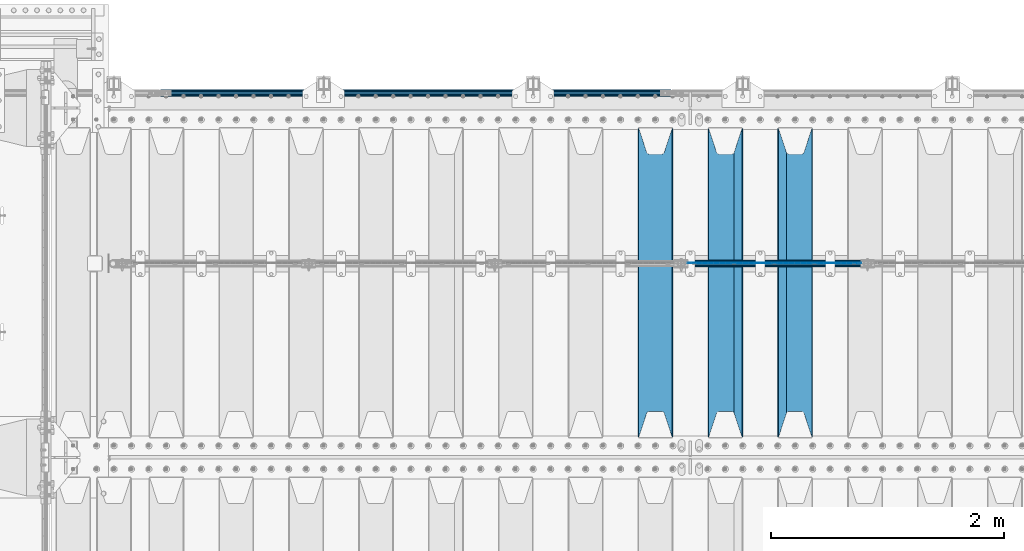
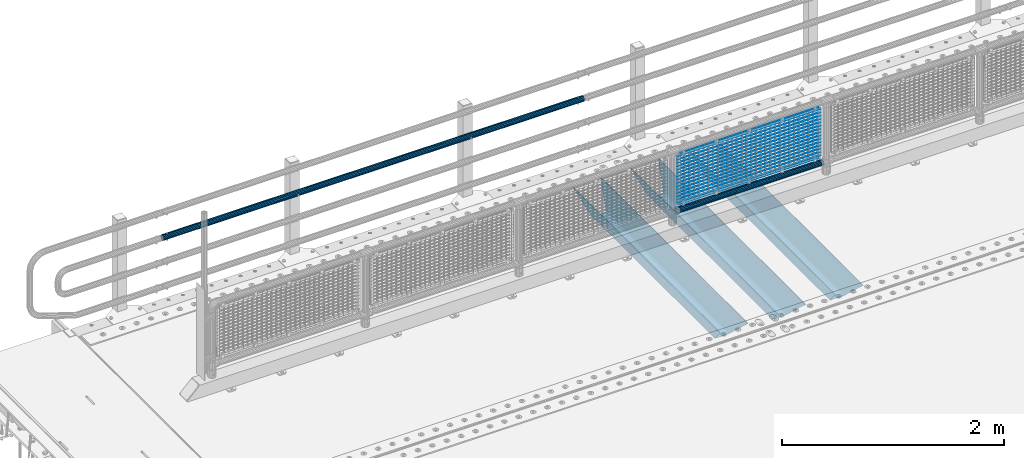
# One storey, part 123 of 247: 22 beams.
"""IFC2X3 building model written with IfcOpenShell, lengths in millimetres."""

from ifc_helpers import new_model, si_unit, frame, origin_with_axes, place, context, subcontext, project, spatial, faceted_brep, material, type_object, element, save


model = new_model("IFC2X3")

# Units and contexts
model_context = context("Model", 3, precision=1e-05, world=origin_with_axes())
body_context = subcontext(model_context, "Body", "Model", "MODEL_VIEW")
ifc_project = project(units=[si_unit("LENGTHUNIT", "METRE", prefix="MILLI"), si_unit("AREAUNIT", "SQUARE_METRE"), si_unit("VOLUMEUNIT", "CUBIC_METRE"), si_unit("MASSUNIT", "GRAM", prefix="KILO"), si_unit("TIMEUNIT", "SECOND"), si_unit("PLANEANGLEUNIT", "RADIAN"), si_unit("SOLIDANGLEUNIT", "STERADIAN"), si_unit("THERMODYNAMICTEMPERATUREUNIT", "DEGREE_CELSIUS"), si_unit("LUMINOUSINTENSITYUNIT", "LUMEN")], contexts=[model_context])

# Site, building, storey
site_placement = place(None, origin_with_axes())
site = spatial("IfcSite", under=ifc_project, at=site_placement, CompositionType="ELEMENT")
building_placement = place(site_placement, origin_with_axes())
building = spatial("IfcBuilding", under=site, at=building_placement, Name="Standard", CompositionType="ELEMENT")
storey_placement = place(building_placement, origin_with_axes())
storey = spatial("IfcBuildingStorey", under=building, at=storey_placement, Name="Undefined", CompositionType="ELEMENT", Elevation=0.0)

# Beams
ifc_material_1 = material(Name="STEEL/S355N")
beam_type_1 = type_object("IfcBeamType", PredefinedType="NOTDEFINED")
beam_1_placement = place(storey_placement, frame((6400.0, 6175.0, -115.0), z_axis=(0.0, 0.0, 1.0), x_axis=(0.0, 1.0, 0.0)))
element("IfcBeam", 1, at=beam_1_placement, inside=storey, type_object=beam_type_1, material=ifc_material_1, context=body_context, shape_type="Brep", body=[
    faceted_brep([(0.0, 150.0, 115.0), (0.0, 143.689999999999, 115.0), (2650.00000000297, 143.689999999999, 115.0), (2650.00000000297, 150.0, 115.0), (2650.00000000297, 142.059565218402, 110.0000000031), (2650.00000000297, 148.369565218403, 110.0000000031), (2441.90079219208, -80.1103600731112, -98.0992078077845), (2437.7588105432, -77.5672621345584, -102.241189456673), (2434.06523489746, -74.4080125315522, -105.934765102404), (2430.91086095089, -70.710272125576, -109.089139048974), (2428.37322971128, -66.5649389910068, -111.626770288588), (2426.51472138054, -62.0739139532889, -113.485278619323), (2425.38102192091, -57.3475956567672, -114.618978078955), (2424.99999999987, -52.5021667386536, -115.0), (2424.99999999987, 52.5021667386536, -115.0), (2425.38102192091, 57.3475956567672, -114.618978078955), (2426.51472138054, 62.0739139532889, -113.485278619323), (2428.37322971128, 66.5649389910068, -111.626770288588), (2430.91086095089, 70.710272125576, -109.089139048974), (2434.06523489746, 74.4080125315522, -105.934765102404), (2437.7588105432, 77.5672621345584, -102.241189456673), (2441.90079219208, 80.1103600731112, -98.0992078077846), (2446.38936140511, 81.9747917625791, -93.6106385947584), (2448.24948500409, 76.2713538057251, -91.7505149957729), (2444.62967112262, 74.76777986261, -95.3703288772456), (2441.28936334126, 72.7168944282894, -98.710636658607), (2438.31067330438, 70.1691124903846, -101.689326695487), (2435.76682334747, 67.1870637758839, -104.233176652398), (2433.72034654133, 63.8440531834895, -106.279653458539), (2432.22154950041, 60.222258798236, -107.778450499454), (2431.30727574265, 56.4107117849089, -108.692724257221), (2430.99999999987, 52.5031078186876, -109.0), (2430.99999999987, -52.5031078186876, -109.0), (2431.30727574265, -56.4107117849089, -108.692724257221), (2432.22154950041, -60.222258798236, -107.778450499454), (2433.72034654133, -63.8440531834895, -106.279653458539), (2435.76682334747, -67.1870637758839, -104.233176652398), (2438.31067330438, -70.1691124903846, -101.689326695487), (2441.28936334126, -72.7168944282894, -98.7106366586071), (2444.62967112262, -74.76777986261, -95.3703288772457), (2448.24948500409, -76.2713538057251, -91.7505149957729), (2650.00000000297, -142.059565218402, 110.0000000031), (2650.00000000297, -148.369565218403, 110.0000000031), (2446.38936140511, -81.9747917625791, -93.6106385947584), (2650.00000000297, -143.689999999999, 115.0), (2650.00000000297, -150.0, 115.0), (0.0, -143.689999999999, 115.0), (0.0, -150.0, 115.0), (0.0, -148.369565218261, 110.000000002663), (203.610638597422, -81.9747917625791, -93.6106385947584), (208.099207810448, -80.1103600731112, -98.0992078077845), (212.241189459336, -77.5672621345584, -102.241189456673), (215.934765105068, -74.4080125315522, -105.934765102404), (219.089139051637, -70.710272125576, -109.089139048974), (221.626770291251, -66.5649389910068, -111.626770288588), (223.485278621985, -62.0739139532889, -113.485278619323), (224.618978081617, -57.3475956567672, -114.618978078955), (225.000000002663, -52.5021667386536, -115.0), (225.000000002663, 52.5021667386536, -115.0), (224.618978081617, 57.3475956567672, -114.618978078955), (223.485278621985, 62.0739139532889, -113.485278619323), (221.626770291251, 66.5649389910068, -111.626770288588), (219.089139051637, 70.710272125576, -109.089139048974), (215.934765105068, 74.4080125315522, -105.934765102404), (212.241189459336, 77.5672621345584, -102.241189456673), (208.099207810448, 80.1103600731112, -98.0992078077846), (203.610638597422, 81.9747917625791, -93.6106385947584), (0.0, 148.369565218261, 110.000000002663), (0.0, 142.05956521826, 110.000000002663), (201.750514998436, 76.2713538057251, -91.7505149957729), (205.370328879908, 74.76777986261, -95.3703288772456), (208.710636661271, 72.7168944282894, -98.710636658607), (211.68932669815, 70.1691124903846, -101.689326695487), (214.233176655061, 67.1870637758839, -104.233176652398), (216.279653461202, 63.8440531834895, -106.279653458539), (217.778450502117, 60.222258798236, -107.778450499454), (218.692724259885, 56.4107117849089, -108.692724257221), (219.000000002663, 52.5031078186876, -109.0), (219.000000002663, -52.5031078186876, -109.0), (218.692724259885, -56.4107117849089, -108.692724257221), (217.778450502117, -60.222258798236, -107.778450499454), (216.279653461202, -63.8440531834895, -106.279653458539), (214.233176655061, -67.1870637758839, -104.233176652398), (211.68932669815, -70.1691124903846, -101.689326695487), (208.710636661271, -72.7168944282894, -98.7106366586071), (205.370328879908, -74.76777986261, -95.3703288772457), (201.750514998436, -76.2713538057251, -91.7505149957729), (0.0, -142.05956521826, 110.000000002663)], [[[0, 1, 2, 3]], [[3, 2, 4, 5]], [[6, 7, 8, 9, 10, 11, 12, 13, 14, 15, 16, 17, 18, 19, 20, 21, 22, 5, 4, 23, 24, 25, 26, 27, 28, 29, 30, 31, 32, 33, 34, 35, 36, 37, 38, 39, 40, 41, 42, 43]], [[44, 45, 42, 41]], [[46, 47, 45, 44]], [[43, 42, 45, 47, 48, 49]], [[6, 43, 49, 50]], [[7, 6, 50, 51]], [[8, 7, 51, 52]], [[9, 8, 52, 53]], [[10, 9, 53, 54]], [[11, 10, 54, 55]], [[12, 11, 55, 56]], [[13, 12, 56, 57]], [[14, 13, 57, 58]], [[15, 14, 58, 59]], [[16, 15, 59, 60]], [[17, 16, 60, 61]], [[18, 17, 61, 62]], [[19, 18, 62, 63]], [[20, 19, 63, 64]], [[21, 20, 64, 65]], [[22, 21, 65, 66]], [[0, 3, 5, 22, 66, 67]], [[1, 0, 67, 68]], [[23, 4, 2, 1, 68, 69]], [[24, 23, 69, 70]], [[25, 24, 70, 71]], [[26, 25, 71, 72]], [[27, 26, 72, 73]], [[28, 27, 73, 74]], [[29, 28, 74, 75]], [[30, 29, 75, 76]], [[31, 30, 76, 77]], [[32, 31, 77, 78]], [[33, 32, 78, 79]], [[34, 33, 79, 80]], [[35, 34, 80, 81]], [[36, 35, 81, 82]], [[37, 36, 82, 83]], [[38, 37, 83, 84]], [[39, 38, 84, 85]], [[40, 39, 85, 86]], [[46, 44, 41, 40, 86, 87]], [[47, 46, 87, 48]], [[86, 85, 84, 83, 82, 81, 80, 79, 78, 77, 76, 75, 74, 73, 72, 71, 70, 69, 68, 67, 66, 65, 64, 63, 62, 61, 60, 59, 58, 57, 56, 55, 54, 53, 52, 51, 50, 49, 48, 87]]]),
])
beam_2_placement = place(storey_placement, frame((5800.0, 6175.0, -115.0), z_axis=(0.0, 0.0, 1.0), x_axis=(0.0, 1.0, 0.0)))
element("IfcBeam", 2, at=beam_2_placement, inside=storey, type_object=beam_type_1, material=ifc_material_1, context=body_context, shape_type="Brep", body=[
    faceted_brep([(0.0, 150.0, 115.0), (0.0, 143.689999999999, 115.0), (2650.00000000297, 143.689999999999, 115.0), (2650.00000000297, 150.0, 115.0), (2650.00000000297, 142.059565218402, 110.0000000031), (2650.00000000297, 148.369565218403, 110.0000000031), (2441.90079219208, -80.1103600731112, -98.0992078077845), (2437.7588105432, -77.5672621345584, -102.241189456673), (2434.06523489746, -74.4080125315522, -105.934765102404), (2430.91086095089, -70.710272125576, -109.089139048974), (2428.37322971128, -66.5649389910068, -111.626770288588), (2426.51472138054, -62.0739139532889, -113.485278619323), (2425.38102192091, -57.3475956567672, -114.618978078955), (2424.99999999987, -52.5021667386536, -115.0), (2424.99999999987, 52.5021667386536, -115.0), (2425.38102192091, 57.3475956567672, -114.618978078955), (2426.51472138054, 62.0739139532889, -113.485278619323), (2428.37322971128, 66.5649389910068, -111.626770288588), (2430.91086095089, 70.710272125576, -109.089139048974), (2434.06523489746, 74.4080125315522, -105.934765102404), (2437.7588105432, 77.5672621345584, -102.241189456673), (2441.90079219208, 80.1103600731112, -98.0992078077846), (2446.38936140511, 81.9747917625791, -93.6106385947584), (2448.24948500409, 76.2713538057251, -91.7505149957729), (2444.62967112262, 74.76777986261, -95.3703288772456), (2441.28936334126, 72.7168944282894, -98.710636658607), (2438.31067330438, 70.1691124903846, -101.689326695487), (2435.76682334747, 67.1870637758839, -104.233176652398), (2433.72034654133, 63.8440531834895, -106.279653458539), (2432.22154950041, 60.222258798236, -107.778450499454), (2431.30727574265, 56.4107117849089, -108.692724257221), (2430.99999999987, 52.5031078186876, -109.0), (2430.99999999987, -52.5031078186876, -109.0), (2431.30727574265, -56.4107117849089, -108.692724257221), (2432.22154950041, -60.222258798236, -107.778450499454), (2433.72034654133, -63.8440531834895, -106.279653458539), (2435.76682334747, -67.1870637758839, -104.233176652398), (2438.31067330438, -70.1691124903846, -101.689326695487), (2441.28936334126, -72.7168944282894, -98.7106366586071), (2444.62967112262, -74.76777986261, -95.3703288772457), (2448.24948500409, -76.2713538057251, -91.7505149957729), (2650.00000000297, -142.059565218402, 110.0000000031), (2650.00000000297, -148.369565218403, 110.0000000031), (2446.38936140511, -81.9747917625791, -93.6106385947584), (2650.00000000297, -143.689999999999, 115.0), (2650.00000000297, -150.0, 115.0), (0.0, -143.689999999999, 115.0), (0.0, -150.0, 115.0), (0.0, -148.369565218261, 110.000000002663), (203.610638597422, -81.9747917625791, -93.6106385947584), (208.099207810448, -80.1103600731112, -98.0992078077845), (212.241189459336, -77.5672621345584, -102.241189456673), (215.934765105068, -74.4080125315522, -105.934765102404), (219.089139051637, -70.710272125576, -109.089139048974), (221.626770291251, -66.5649389910068, -111.626770288588), (223.485278621985, -62.0739139532889, -113.485278619323), (224.618978081617, -57.3475956567672, -114.618978078955), (225.000000002663, -52.5021667386536, -115.0), (225.000000002663, 52.5021667386536, -115.0), (224.618978081617, 57.3475956567672, -114.618978078955), (223.485278621985, 62.0739139532889, -113.485278619323), (221.626770291251, 66.5649389910068, -111.626770288588), (219.089139051637, 70.710272125576, -109.089139048974), (215.934765105068, 74.4080125315522, -105.934765102404), (212.241189459336, 77.5672621345584, -102.241189456673), (208.099207810448, 80.1103600731112, -98.0992078077846), (203.610638597422, 81.9747917625791, -93.6106385947584), (0.0, 148.369565218261, 110.000000002663), (0.0, 142.05956521826, 110.000000002663), (201.750514998436, 76.2713538057251, -91.7505149957729), (205.370328879908, 74.76777986261, -95.3703288772456), (208.710636661271, 72.7168944282894, -98.710636658607), (211.68932669815, 70.1691124903846, -101.689326695487), (214.233176655061, 67.1870637758839, -104.233176652398), (216.279653461202, 63.8440531834895, -106.279653458539), (217.778450502117, 60.222258798236, -107.778450499454), (218.692724259885, 56.4107117849089, -108.692724257221), (219.000000002663, 52.5031078186876, -109.0), (219.000000002663, -52.5031078186876, -109.0), (218.692724259885, -56.4107117849089, -108.692724257221), (217.778450502117, -60.222258798236, -107.778450499454), (216.279653461202, -63.8440531834895, -106.279653458539), (214.233176655061, -67.1870637758839, -104.233176652398), (211.68932669815, -70.1691124903846, -101.689326695487), (208.710636661271, -72.7168944282894, -98.7106366586071), (205.370328879908, -74.76777986261, -95.3703288772457), (201.750514998436, -76.2713538057251, -91.7505149957729), (0.0, -142.05956521826, 110.000000002663)], [[[0, 1, 2, 3]], [[3, 2, 4, 5]], [[6, 7, 8, 9, 10, 11, 12, 13, 14, 15, 16, 17, 18, 19, 20, 21, 22, 5, 4, 23, 24, 25, 26, 27, 28, 29, 30, 31, 32, 33, 34, 35, 36, 37, 38, 39, 40, 41, 42, 43]], [[44, 45, 42, 41]], [[46, 47, 45, 44]], [[43, 42, 45, 47, 48, 49]], [[6, 43, 49, 50]], [[7, 6, 50, 51]], [[8, 7, 51, 52]], [[9, 8, 52, 53]], [[10, 9, 53, 54]], [[11, 10, 54, 55]], [[12, 11, 55, 56]], [[13, 12, 56, 57]], [[14, 13, 57, 58]], [[15, 14, 58, 59]], [[16, 15, 59, 60]], [[17, 16, 60, 61]], [[18, 17, 61, 62]], [[19, 18, 62, 63]], [[20, 19, 63, 64]], [[21, 20, 64, 65]], [[22, 21, 65, 66]], [[0, 3, 5, 22, 66, 67]], [[1, 0, 67, 68]], [[23, 4, 2, 1, 68, 69]], [[24, 23, 69, 70]], [[25, 24, 70, 71]], [[26, 25, 71, 72]], [[27, 26, 72, 73]], [[28, 27, 73, 74]], [[29, 28, 74, 75]], [[30, 29, 75, 76]], [[31, 30, 76, 77]], [[32, 31, 77, 78]], [[33, 32, 78, 79]], [[34, 33, 79, 80]], [[35, 34, 80, 81]], [[36, 35, 81, 82]], [[37, 36, 82, 83]], [[38, 37, 83, 84]], [[39, 38, 84, 85]], [[40, 39, 85, 86]], [[46, 44, 41, 40, 86, 87]], [[47, 46, 87, 48]], [[86, 85, 84, 83, 82, 81, 80, 79, 78, 77, 76, 75, 74, 73, 72, 71, 70, 69, 68, 67, 66, 65, 64, 63, 62, 61, 60, 59, 58, 57, 56, 55, 54, 53, 52, 51, 50, 49, 48, 87]]]),
])
beam_3_placement = place(storey_placement, frame((5200.0, 6175.0, -115.0), z_axis=(0.0, 0.0, 1.0), x_axis=(0.0, 1.0, 0.0)))
element("IfcBeam", 3, at=beam_3_placement, inside=storey, type_object=beam_type_1, material=ifc_material_1, context=body_context, shape_type="Brep", body=[
    faceted_brep([(0.0, 150.0, 115.0), (0.0, 143.689999999999, 115.0), (2650.00000000297, 143.689999999999, 115.0), (2650.00000000297, 150.0, 115.0), (2650.00000000297, 142.059565218402, 110.0000000031), (2650.00000000297, 148.369565218403, 110.0000000031), (2441.90079219208, -80.1103600731112, -98.0992078077845), (2437.7588105432, -77.5672621345584, -102.241189456673), (2434.06523489746, -74.4080125315522, -105.934765102404), (2430.91086095089, -70.710272125576, -109.089139048974), (2428.37322971128, -66.5649389910068, -111.626770288588), (2426.51472138054, -62.0739139532889, -113.485278619323), (2425.38102192091, -57.3475956567672, -114.618978078955), (2424.99999999987, -52.5021667386536, -115.0), (2424.99999999987, 52.5021667386536, -115.0), (2425.38102192091, 57.3475956567672, -114.618978078955), (2426.51472138054, 62.0739139532889, -113.485278619323), (2428.37322971128, 66.5649389910068, -111.626770288588), (2430.91086095089, 70.710272125576, -109.089139048974), (2434.06523489746, 74.4080125315522, -105.934765102404), (2437.7588105432, 77.5672621345584, -102.241189456673), (2441.90079219208, 80.1103600731112, -98.0992078077846), (2446.38936140511, 81.9747917625791, -93.6106385947584), (2448.24948500409, 76.2713538057251, -91.7505149957729), (2444.62967112262, 74.76777986261, -95.3703288772456), (2441.28936334126, 72.7168944282894, -98.710636658607), (2438.31067330438, 70.1691124903846, -101.689326695487), (2435.76682334747, 67.1870637758839, -104.233176652398), (2433.72034654133, 63.8440531834895, -106.279653458539), (2432.22154950041, 60.222258798236, -107.778450499454), (2431.30727574265, 56.4107117849089, -108.692724257221), (2430.99999999987, 52.5031078186876, -109.0), (2430.99999999987, -52.5031078186876, -109.0), (2431.30727574265, -56.4107117849089, -108.692724257221), (2432.22154950041, -60.222258798236, -107.778450499454), (2433.72034654133, -63.8440531834895, -106.279653458539), (2435.76682334747, -67.1870637758839, -104.233176652398), (2438.31067330438, -70.1691124903846, -101.689326695487), (2441.28936334126, -72.7168944282894, -98.7106366586071), (2444.62967112262, -74.76777986261, -95.3703288772457), (2448.24948500409, -76.2713538057251, -91.7505149957729), (2650.00000000297, -142.059565218402, 110.0000000031), (2650.00000000297, -148.369565218403, 110.0000000031), (2446.38936140511, -81.9747917625791, -93.6106385947584), (2650.00000000297, -143.689999999999, 115.0), (2650.00000000297, -150.0, 115.0), (0.0, -143.689999999999, 115.0), (0.0, -150.0, 115.0), (0.0, -148.369565218261, 110.000000002663), (203.610638597422, -81.9747917625791, -93.6106385947584), (208.099207810448, -80.1103600731112, -98.0992078077845), (212.241189459336, -77.5672621345584, -102.241189456673), (215.934765105068, -74.4080125315522, -105.934765102404), (219.089139051637, -70.710272125576, -109.089139048974), (221.626770291251, -66.5649389910068, -111.626770288588), (223.485278621985, -62.0739139532889, -113.485278619323), (224.618978081617, -57.3475956567672, -114.618978078955), (225.000000002663, -52.5021667386536, -115.0), (225.000000002663, 52.5021667386536, -115.0), (224.618978081617, 57.3475956567672, -114.618978078955), (223.485278621985, 62.0739139532889, -113.485278619323), (221.626770291251, 66.5649389910068, -111.626770288588), (219.089139051637, 70.710272125576, -109.089139048974), (215.934765105068, 74.4080125315522, -105.934765102404), (212.241189459336, 77.5672621345584, -102.241189456673), (208.099207810448, 80.1103600731112, -98.0992078077846), (203.610638597422, 81.9747917625791, -93.6106385947584), (0.0, 148.369565218261, 110.000000002663), (0.0, 142.05956521826, 110.000000002663), (201.750514998436, 76.2713538057251, -91.7505149957729), (205.370328879908, 74.76777986261, -95.3703288772456), (208.710636661271, 72.7168944282894, -98.710636658607), (211.68932669815, 70.1691124903846, -101.689326695487), (214.233176655061, 67.1870637758839, -104.233176652398), (216.279653461202, 63.8440531834895, -106.279653458539), (217.778450502117, 60.222258798236, -107.778450499454), (218.692724259885, 56.4107117849089, -108.692724257221), (219.000000002663, 52.5031078186876, -109.0), (219.000000002663, -52.5031078186876, -109.0), (218.692724259885, -56.4107117849089, -108.692724257221), (217.778450502117, -60.222258798236, -107.778450499454), (216.279653461202, -63.8440531834895, -106.279653458539), (214.233176655061, -67.1870637758839, -104.233176652398), (211.68932669815, -70.1691124903846, -101.689326695487), (208.710636661271, -72.7168944282894, -98.7106366586071), (205.370328879908, -74.76777986261, -95.3703288772457), (201.750514998436, -76.2713538057251, -91.7505149957729), (0.0, -142.05956521826, 110.000000002663)], [[[0, 1, 2, 3]], [[3, 2, 4, 5]], [[6, 7, 8, 9, 10, 11, 12, 13, 14, 15, 16, 17, 18, 19, 20, 21, 22, 5, 4, 23, 24, 25, 26, 27, 28, 29, 30, 31, 32, 33, 34, 35, 36, 37, 38, 39, 40, 41, 42, 43]], [[44, 45, 42, 41]], [[46, 47, 45, 44]], [[43, 42, 45, 47, 48, 49]], [[6, 43, 49, 50]], [[7, 6, 50, 51]], [[8, 7, 51, 52]], [[9, 8, 52, 53]], [[10, 9, 53, 54]], [[11, 10, 54, 55]], [[12, 11, 55, 56]], [[13, 12, 56, 57]], [[14, 13, 57, 58]], [[15, 14, 58, 59]], [[16, 15, 59, 60]], [[17, 16, 60, 61]], [[18, 17, 61, 62]], [[19, 18, 62, 63]], [[20, 19, 63, 64]], [[21, 20, 64, 65]], [[22, 21, 65, 66]], [[0, 3, 5, 22, 66, 67]], [[1, 0, 67, 68]], [[23, 4, 2, 1, 68, 69]], [[24, 23, 69, 70]], [[25, 24, 70, 71]], [[26, 25, 71, 72]], [[27, 26, 72, 73]], [[28, 27, 73, 74]], [[29, 28, 74, 75]], [[30, 29, 75, 76]], [[31, 30, 76, 77]], [[32, 31, 77, 78]], [[33, 32, 78, 79]], [[34, 33, 79, 80]], [[35, 34, 80, 81]], [[36, 35, 81, 82]], [[37, 36, 82, 83]], [[38, 37, 83, 84]], [[39, 38, 84, 85]], [[40, 39, 85, 86]], [[46, 44, 41, 40, 86, 87]], [[47, 46, 87, 48]], [[86, 85, 84, 83, 82, 81, 80, 79, 78, 77, 76, 75, 74, 73, 72, 71, 70, 69, 68, 67, 66, 65, 64, 63, 62, 61, 60, 59, 58, 57, 56, 55, 54, 53, 52, 51, 50, 49, 48, 87]]]),
])
ifc_material_2 = material()
beam_type_2 = type_object("IfcBeamType", PredefinedType="NOTDEFINED")
beam_4_placement = place(storey_placement, frame((5333.99999999987, 9129.85000000009, 689.849999999725), z_axis=(0.0, 0.0, -1.0), x_axis=(-1.0, 0.0, 0.0)))
element("IfcBeam", 4, at=beam_4_placement, inside=storey, type_object=beam_type_2, material=ifc_material_2, context=body_context, shape_type="Brep", body=[
    faceted_brep([(0.0, -26.5499999999993, 0.0), (0.0, -24.5290015881747, 10.1602451292931), (4384.00249699992, -24.5290015881747, 10.1602451292931), (4384.00249699992, -26.5499999999993, 0.0), (0.0, -18.7736850405036, 18.7736850405028), (4384.00249699992, -18.7736850405036, 18.7736850405028), (0.0, -10.1602451292929, 24.5290015881747), (4384.00249699992, -10.1602451292929, 24.5290015881747), (0.0, 0.0, 26.55), (4384.00249699992, 0.0, 26.55), (0.0, 10.1602451292929, 24.5290015881747), (4384.00249699992, 10.1602451292929, 24.5290015881747), (0.0, 18.7736850405036, 18.7736850405028), (4384.00249699992, 18.7736850405036, 18.7736850405028), (0.0, 24.5290015881747, 10.1602451292931), (4384.00249699992, 24.5290015881747, 10.1602451292931), (0.0, 26.5499999999993, 0.0), (4384.00249699992, 26.5499999999993, 0.0), (0.0, 24.5290015881747, -10.1602451292931), (4384.00249699992, 24.5290015881747, -10.1602451292931), (0.0, 18.7736850405036, -18.7736850405028), (4384.00249699992, 18.7736850405036, -18.7736850405028), (0.0, 10.1602451292929, -24.5290015881747), (4384.00249699992, 10.1602451292929, -24.5290015881747), (0.0, 0.0, -26.55), (4384.00249699992, 0.0, -26.55), (0.0, -10.1602451292929, -24.5290015881747), (4384.00249699992, -10.1602451292929, -24.5290015881747), (0.0, -18.7736850405036, -18.7736850405028), (4384.00249699992, -18.7736850405036, -18.7736850405028), (0.0, -24.5290015881747, -10.1602451292931), (4384.00249699992, -24.5290015881747, -10.1602451292931), (0.0, -30.1499999999996, 0.0), (0.0, -27.8549679052148, -11.5379054858076), (4384.00249699992, -27.8549679052157, -11.5379054858075), (4384.00249699992, -30.1499999999996, 0.0), (0.0, -21.3192694527743, -21.3192694527752), (4384.00249699992, -21.3192694527752, -21.3192694527744), (0.0, -11.5379054858076, -27.8549679052157), (4384.00249699992, -11.5379054858076, -27.8549679052153), (0.0, 0.0, -30.1499999999996), (4384.00249699992, 0.0, -30.15), (0.0, 11.5379054858076, -27.8549679052157), (4384.00249699992, 11.5379054858076, -27.8549679052153), (0.0, 21.3192694527743, -21.3192694527752), (4384.00249699992, 21.3192694527752, -21.3192694527744), (0.0, 27.8549679052157, -11.5379054858076), (4384.00249699992, 27.8549679052157, -11.5379054858074), (0.0, 30.1499999999996, 0.0), (4384.00249699992, 30.1499999999996, 0.0), (0.0, 27.8549679052157, 11.5379054858076), (4384.00249699992, 27.8549679052157, 11.5379054858075), (0.0, 21.3192694527743, 21.3192694527752), (4384.00249699992, 21.3192694527752, 21.3192694527744), (0.0, 11.5379054858076, 27.8549679052157), (4384.00249699992, 11.5379054858076, 27.8549679052153), (0.0, 0.0, 30.1499999999996), (4384.00249699992, 0.0, 30.15), (0.0, -11.5379054858076, 27.8549679052157), (4384.00249699992, -11.5379054858076, 27.8549679052153), (0.0, -21.3192694527743, 21.3192694527752), (4384.00249699992, -21.3192694527752, 21.3192694527744), (0.0, -27.8549679052157, 11.5379054858076), (4384.00249699992, -27.8549679052157, 11.5379054858075)], [[[0, 1, 2, 3]], [[1, 4, 5, 2]], [[4, 6, 7, 5]], [[6, 8, 9, 7]], [[8, 10, 11, 9]], [[10, 12, 13, 11]], [[12, 14, 15, 13]], [[14, 16, 17, 15]], [[16, 18, 19, 17]], [[18, 20, 21, 19]], [[20, 22, 23, 21]], [[22, 24, 25, 23]], [[24, 26, 27, 25]], [[26, 28, 29, 27]], [[28, 30, 31, 29]], [[30, 0, 3, 31]], [[32, 33, 34, 35]], [[33, 36, 37, 34]], [[36, 38, 39, 37]], [[38, 40, 41, 39]], [[40, 42, 43, 41]], [[42, 44, 45, 43]], [[44, 46, 47, 45]], [[46, 48, 49, 47]], [[48, 50, 51, 49]], [[50, 52, 53, 51]], [[52, 54, 55, 53]], [[54, 56, 57, 55]], [[56, 58, 59, 57]], [[58, 60, 61, 59]], [[60, 62, 63, 61]], [[62, 32, 35, 63]], [[37, 39, 41, 43, 45, 47, 49, 51, 53, 55, 57, 59, 61, 63, 35, 34], [5, 7, 9, 11, 13, 15, 17, 19, 21, 23, 25, 27, 29, 31, 3, 2]], [[62, 60, 58, 56, 54, 52, 50, 48, 46, 44, 42, 40, 38, 36, 33, 32], [30, 28, 26, 24, 22, 20, 18, 16, 14, 12, 10, 8, 6, 4, 1, 0]]]),
])
beam_type_3 = type_object("IfcBeamType", PredefinedType="NOTDEFINED")
beam_5_placement = place(storey_placement, frame((5455.85000000001, 7664.5, 298.170000000003), z_axis=(0.0, 0.0, 1.0), x_axis=(1.0, 0.0, 0.0)))
element("IfcBeam", 5, at=beam_5_placement, inside=storey, type_object=beam_type_3, material=ifc_material_2, context=body_context, shape_type="Brep", body=[
    faceted_brep([(0.0, -25.3500000000004, 0.0), (0.0, -23.4203461491616, 9.70102501045585), (1530.0, -23.4203461491616, 9.70102501045506), (1530.0, -25.3500000000004, 0.0), (0.0, -17.9251569030794, 17.9251569030785), (1530.0, -17.9251569030794, 17.925156903079), (0.0, -9.70102501045494, 23.4203461491616), (1530.0, -9.70102501045494, 23.4203461491611), (0.0, 0.0, 25.3500000000004), (1530.0, 0.0, 25.35), (0.0, 9.70102501045494, 23.4203461491616), (1530.0, 9.70102501045494, 23.4203461491611), (0.0, 17.9251569030794, 17.9251569030785), (1530.0, 17.9251569030794, 17.925156903079), (0.0, 23.4203461491616, 9.70102501045585), (1530.0, 23.4203461491616, 9.70102501045506), (0.0, 25.3500000000004, 0.0), (1530.0, 25.3500000000004, 0.0), (0.0, 23.4203461491616, -9.70102501045585), (1530.0, 23.4203461491616, -9.70102501045506), (0.0, 17.9251569030794, -17.9251569030785), (1530.0, 17.9251569030794, -17.925156903079), (0.0, 9.70102501045494, -23.4203461491616), (1530.0, 9.70102501045494, -23.4203461491611), (0.0, 0.0, -25.3500000000004), (1530.0, 0.0, -25.35), (0.0, -9.70102501045494, -23.4203461491616), (1530.0, -9.70102501045494, -23.4203461491611), (0.0, -17.9251569030794, -17.9251569030785), (1530.0, -17.9251569030794, -17.925156903079), (0.0, -23.4203461491616, -9.70102501045585), (1530.0, -23.4203461491616, -9.70102501045506), (0.0, -30.1499999999996, 0.0), (0.0, -27.8549679052148, -11.5379054858076), (1530.0, -27.8549679052148, -11.5379054858075), (1530.0, -30.1499999999996, 0.0), (0.0, -21.3192694527743, -21.3192694527752), (1530.0, -21.3192694527743, -21.3192694527744), (0.0, -11.5379054858076, -27.8549679052157), (1530.0, -11.5379054858076, -27.8549679052153), (0.0, 0.0, -30.1499999999996), (1530.0, 0.0, -30.15), (0.0, 11.5379054858076, -27.8549679052157), (1530.0, 11.5379054858076, -27.8549679052153), (0.0, 21.3192694527743, -21.3192694527752), (1530.0, 21.3192694527743, -21.3192694527744), (0.0, 27.8549679052157, -11.5379054858076), (1530.0, 27.8549679052157, -11.5379054858074), (0.0, 30.1499999999996, 0.0), (1530.0, 30.1499999999996, 0.0), (0.0, 27.8549679052157, 11.5379054858076), (1530.0, 27.8549679052157, 11.5379054858074), (0.0, 21.3192694527743, 21.3192694527752), (1530.0, 21.3192694527743, 21.3192694527744), (0.0, 11.5379054858076, 27.8549679052157), (1530.0, 11.5379054858076, 27.8549679052153), (0.0, 0.0, 30.1499999999996), (1530.0, 0.0, 30.15), (0.0, -11.5379054858076, 27.8549679052157), (1530.0, -11.5379054858076, 27.8549679052153), (0.0, -21.3192694527743, 21.3192694527752), (1530.0, -21.3192694527743, 21.3192694527744), (0.0, -27.8549679052157, 11.5379054858076), (1530.0, -27.8549679052157, 11.5379054858074)], [[[0, 1, 2, 3]], [[1, 4, 5, 2]], [[4, 6, 7, 5]], [[6, 8, 9, 7]], [[8, 10, 11, 9]], [[10, 12, 13, 11]], [[12, 14, 15, 13]], [[14, 16, 17, 15]], [[16, 18, 19, 17]], [[18, 20, 21, 19]], [[20, 22, 23, 21]], [[22, 24, 25, 23]], [[24, 26, 27, 25]], [[26, 28, 29, 27]], [[28, 30, 31, 29]], [[30, 0, 3, 31]], [[32, 33, 34, 35]], [[33, 36, 37, 34]], [[36, 38, 39, 37]], [[38, 40, 41, 39]], [[40, 42, 43, 41]], [[42, 44, 45, 43]], [[44, 46, 47, 45]], [[46, 48, 49, 47]], [[48, 50, 51, 49]], [[50, 52, 53, 51]], [[52, 54, 55, 53]], [[54, 56, 57, 55]], [[56, 58, 59, 57]], [[58, 60, 61, 59]], [[60, 62, 63, 61]], [[62, 32, 35, 63]], [[37, 39, 41, 43, 45, 47, 49, 51, 53, 55, 57, 59, 61, 63, 35, 34], [5, 7, 9, 11, 13, 15, 17, 19, 21, 23, 25, 27, 29, 31, 3, 2]], [[62, 60, 58, 56, 54, 52, 50, 48, 46, 44, 42, 40, 38, 36, 33, 32], [30, 28, 26, 24, 22, 20, 18, 16, 14, 12, 10, 8, 6, 4, 1, 0]]]),
])
ifc_material_3 = material(Name="Misc_Undefined")
beam_type_4 = type_object("IfcBeamType", Name="D3", PredefinedType="NOTDEFINED")
for number, where, z_axis, x_axis in (
    (6, (5476.0, 7670.5, 851.597000000001), (0.0, 0.0, 1.0), (1.0, 0.0, 0.0)),
    (7, (5476.0, 7670.5, 669.452000000001), (0.0, 0.0, 1.0), (1.0, 0.0, 0.0)),
    (8, (5476.0, 7670.5, 523.736000000001), (0.0, 0.0, 1.0), (1.0, 0.0, 0.0)),
    (9, (5476.0, 7670.5, 487.307000000001), (0.0, 0.0, 1.0), (1.0, 0.0, 0.0)),
    (10, (5476.0, 7670.5, 705.881000000001), (0.0, 0.0, 1.0), (1.0, 0.0, 0.0)),
    (11, (5476.0, 7670.5, 596.594000000001), (0.0, 0.0, 1.0), (1.0, 0.0, 0.0)),
    (12, (5476.0, 7670.5, 450.878000000001), (0.0, 0.0, 1.0), (1.0, 0.0, 0.0)),
    (13, (5476.0, 7670.5, 815.168000000001), (0.0, 0.0, 1.0), (1.0, 0.0, 0.0)),
    (14, (5476.0, 7670.5, 888.026000000001), (0.0, 0.0, 1.0), (1.0, 0.0, 0.0)),
    (15, (5476.0, 7670.5, 778.739000000001), (0.0, 0.0, 1.0), (1.0, 0.0, 0.0)),
    (16, (5476.0, 7670.5, 742.310000000001), (0.0, 0.0, 1.0), (1.0, 0.0, 0.0)),
    (17, (5476.0, 7670.5, 633.023000000001), (0.0, 0.0, 1.0), (1.0, 0.0, 0.0)),
    (18, (5476.0, 7670.5, 560.165000000001), (0.0, 0.0, 1.0), (1.0, 0.0, 0.0)),
    (19, (5476.0, 7670.5, 414.449000000001), (0.0, 0.0, 1.0), (1.0, 0.0, 0.0)),
):
    element("IfcBeam", number, at=place(storey_placement, frame(where, z_axis=z_axis, x_axis=x_axis)), inside=storey, type_object=beam_type_4, material=ifc_material_3, ObjectType="D3", context=body_context, shape_type="Brep", body=[
        faceted_brep([(1.81898940354586e-12, -1.5, -5.6843418860808e-14), (0.0, -0.75, -1.29903810567703), (1490.0, -0.75, -1.29903810567669), (1490.0, -1.5, 0.0), (0.0, 0.75, -1.29903810567703), (1490.0, 0.75, -1.29903810567669), (1.81898940354586e-12, 1.5, -5.6843418860808e-14), (1490.0, 1.5, 0.0), (0.0, 0.75, 1.29903810567703), (1490.0, 0.75, 1.29903810567669), (0.0, -0.75, 1.29903810567703), (1490.0, -0.75, 1.29903810567669)], [[[0, 1, 2, 3]], [[1, 4, 5, 2]], [[4, 6, 7, 5]], [[6, 8, 9, 7]], [[8, 10, 11, 9]], [[10, 0, 3, 11]], [[5, 7, 9, 11, 3, 2]], [[10, 8, 6, 4, 1, 0]]]),
    ])
beam_6_placement = place(storey_placement, frame((5501.0, 7670.5, 353.020000000001), z_axis=(0.0, 0.0, 1.0), x_axis=(1.0, 0.0, 0.0)))
element("IfcBeam", 20, at=beam_6_placement, inside=storey, type_object=beam_type_4, material=ifc_material_3, ObjectType="D3", context=body_context, shape_type="Brep", body=[
    faceted_brep([(1.81898940354586e-12, -1.5, -5.6843418860808e-14), (0.0, -0.75, -1.29903810567703), (1440.0, -0.75, -1.29903810567669), (1440.0, -1.5, 0.0), (0.0, 0.75, -1.29903810567703), (1440.0, 0.75, -1.29903810567663), (1.81898940354586e-12, 1.5, -5.6843418860808e-14), (1440.0, 1.5, 0.0), (0.0, 0.75, 1.29903810567703), (1440.0, 0.75, 1.29903810567669), (0.0, -0.75, 1.29903810567703), (1440.0, -0.75, 1.29903810567669)], [[[0, 1, 2, 3]], [[1, 4, 5, 2]], [[4, 6, 7, 5]], [[6, 8, 9, 7]], [[8, 10, 11, 9]], [[10, 0, 3, 11]], [[5, 7, 9, 11, 3, 2]], [[10, 8, 6, 4, 1, 0]]]),
])
beam_7_placement = place(storey_placement, frame((5476.0, 7670.5, 378.020000000001), z_axis=(0.0, 0.0, 1.0), x_axis=(1.0, 0.0, 0.0)))
element("IfcBeam", 21, at=beam_7_placement, inside=storey, type_object=beam_type_4, material=ifc_material_3, ObjectType="D3", context=body_context, shape_type="Brep", body=[
    faceted_brep([(1.81898940354586e-12, -1.5, -5.6843418860808e-14), (0.0, -0.75, -1.29903810567703), (1490.0, -0.75, -1.29903810567669), (1490.0, -1.5, 0.0), (0.0, 0.75, -1.29903810567703), (1490.0, 0.75, -1.29903810567669), (1.81898940354586e-12, 1.5, -5.6843418860808e-14), (1490.0, 1.5, 0.0), (0.0, 0.75, 1.29903810567703), (1490.0, 0.75, 1.29903810567669), (0.0, -0.75, 1.29903810567703), (1490.0, -0.75, 1.29903810567669)], [[[0, 1, 2, 3]], [[1, 4, 5, 2]], [[4, 6, 7, 5]], [[6, 8, 9, 7]], [[8, 10, 11, 9]], [[10, 0, 3, 11]], [[5, 7, 9, 11, 3, 2]], [[10, 8, 6, 4, 1, 0]]]),
])
beam_8_placement = place(storey_placement, frame((5501.0, 7670.5, 913.020000000001), z_axis=(0.0, 0.0, 1.0), x_axis=(1.0, 0.0, 0.0)))
element("IfcBeam", 22, at=beam_8_placement, inside=storey, type_object=beam_type_4, material=ifc_material_3, ObjectType="D3", context=body_context, shape_type="Brep", body=[
    faceted_brep([(1.81898940354586e-12, -1.5, -5.6843418860808e-14), (0.0, -0.75, -1.29903810567703), (1440.0, -0.75, -1.29903810567669), (1440.0, -1.5, 0.0), (0.0, 0.75, -1.29903810567703), (1440.0, 0.75, -1.29903810567663), (1.81898940354586e-12, 1.5, -5.6843418860808e-14), (1440.0, 1.5, 0.0), (0.0, 0.75, 1.29903810567703), (1440.0, 0.75, 1.29903810567669), (0.0, -0.75, 1.29903810567703), (1440.0, -0.75, 1.29903810567669)], [[[0, 1, 2, 3]], [[1, 4, 5, 2]], [[4, 6, 7, 5]], [[6, 8, 9, 7]], [[8, 10, 11, 9]], [[10, 0, 3, 11]], [[5, 7, 9, 11, 3, 2]], [[10, 8, 6, 4, 1, 0]]]),
])

save(model, "model.ifc")
